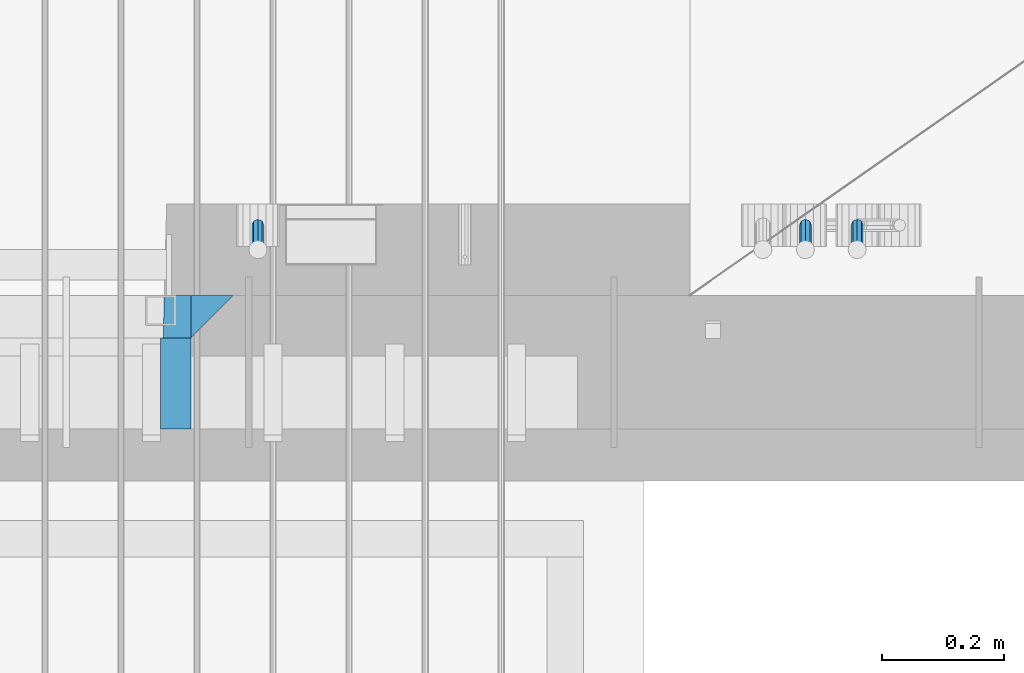
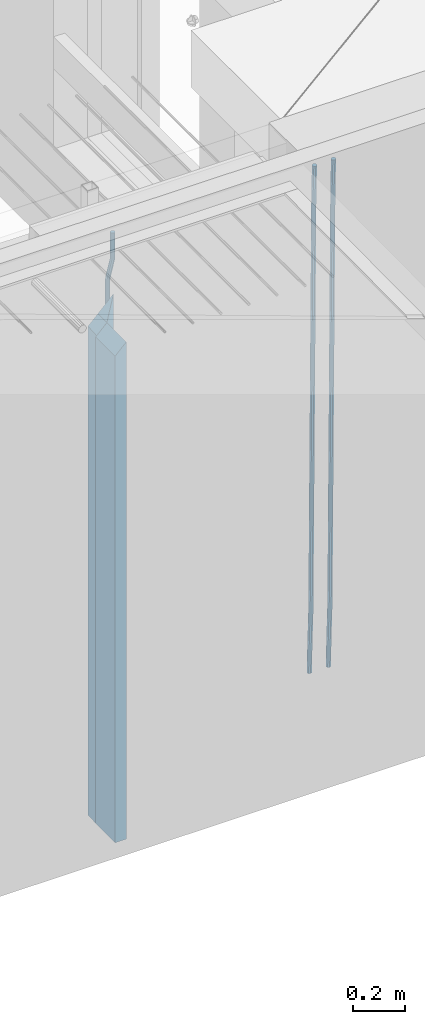
# One storey, part 130 of 349: 6 beams, 1 element without a shape of its own.
"""IFC2X3 building model written with IfcOpenShell, lengths in millimetres."""

from ifc_helpers import new_model, si_unit, frame, origin_with_axes, place, context, subcontext, project, spatial, faceted_brep, material, type_object, element, aggregate, save


model = new_model("IFC2X3")

# Units and contexts
model_context = context("Model", 3, precision=1e-05, world=origin_with_axes())
body_context = subcontext(model_context, "Body", "Model", "MODEL_VIEW")
ifc_project = project(units=[si_unit("LENGTHUNIT", "METRE", prefix="MILLI"), si_unit("AREAUNIT", "SQUARE_METRE"), si_unit("VOLUMEUNIT", "CUBIC_METRE"), si_unit("MASSUNIT", "GRAM", prefix="KILO"), si_unit("TIMEUNIT", "SECOND"), si_unit("PLANEANGLEUNIT", "RADIAN"), si_unit("SOLIDANGLEUNIT", "STERADIAN"), si_unit("THERMODYNAMICTEMPERATUREUNIT", "DEGREE_CELSIUS"), si_unit("LUMINOUSINTENSITYUNIT", "LUMEN")], contexts=[model_context])

# Site, building, storey
site_placement = place(None, origin_with_axes())
site = spatial("IfcSite", under=ifc_project, at=site_placement, CompositionType="ELEMENT")
building_placement = place(site_placement, origin_with_axes())
building = spatial("IfcBuilding", under=site, at=building_placement, CompositionType="ELEMENT")
storey_placement = place(building_placement, origin_with_axes())
storey = spatial("IfcBuildingStorey", under=building, at=storey_placement, Name="4", CompositionType="ELEMENT", Elevation=0.0)

# Assembly, beams
assembly_placement = place(storey_placement, origin_with_axes())
assembly = element("IfcElementAssembly", 1, at=assembly_placement, inside=storey, AssemblyPlace="NOTDEFINED", PredefinedType="REINFORCEMENT_UNIT")
ifc_material_1 = material(Name="CONCRETE/C35/45")
beam_type_1 = type_object("IfcBeamType", PredefinedType="NOTDEFINED")
beam_1_placement = place(assembly_placement, frame((33199.9988923323, 7815.0, 93175.0), z_axis=(-1.0, 3.00000001838171e-08, 0.0), x_axis=(0.0, 0.0, -1.0)))
beam_1 = element("IfcBeam", 2, at=beam_1_placement, type_object=beam_type_1, material=ifc_material_1, Name="SK", context=body_context, shape_type="Brep", body=[
    faceted_brep([(2420.0, -35.0, 35.0), (2420.0, -35.0, -35.0), (2420.0, 35.0, 35.0), (0.0, -35.0, -35.0), (70.0000000000164, 35.0, 35.0), (70.0000000000164, -35.0, 35.0)], [[[0, 1, 2]], [[2, 1, 3, 4]], [[0, 2, 4, 5]], [[1, 0, 5, 3]], [[5, 4, 3]]]),
])
beam_type_2 = type_object("IfcBeamType", PredefinedType="NOTDEFINED")
beam_2_placement = place(assembly_placement, frame((33139.9988923323, 7815.0, 93105.0), z_axis=(-1.0, 3.00000001838171e-08, 0.0), x_axis=(0.0, 0.0, -1.0)))
beam_2 = element("IfcBeam", 3, at=beam_2_placement, type_object=beam_type_2, material=ifc_material_1, Name="SK", context=body_context, shape_type="Brep", body=[
    faceted_brep([(2350.0, -35.0, -25.0), (2350.0, 35.0, -25.0), (2350.0, 35.0, 20.6410256410309), (2350.0, -35.0, 18.8461538461561), (0.0, -35.0, -25.0), (0.0, 35.0, -25.0), (45.6410256410309, 35.0, 20.6410256410254), (43.8461538461561, -35.0, 18.8461538461543)], [[[0, 1, 2, 3]], [[1, 0, 4, 5]], [[2, 1, 5, 6]], [[3, 2, 6, 7]], [[0, 3, 7, 4]], [[6, 5, 4, 7]]]),
])
ifc_material_2 = material(Name="TIMBER")
beam_type_3 = type_object("IfcBeamType", Name="50X150", PredefinedType="NOTDEFINED")
beam_3_placement = place(assembly_placement, frame((33139.9988923323, 7705.0, 93105.0), z_axis=(-1.0, 3.00000001838171e-08, 0.0), x_axis=(0.0, 0.0, -1.0)))
beam_3 = element("IfcBeam", 4, at=beam_3_placement, type_object=beam_type_3, material=ifc_material_2, ObjectType="50X150", context=body_context, shape_type="Brep", body=[
    faceted_brep([(2345.0, -75.0, 25.0), (2345.0, -75.0, -25.0), (2345.0, 75.0, -25.0), (2345.0, 75.0, 25.0), (0.0, -75.0, -25.0), (0.0, 75.0, -25.0), (50.0000000000036, 75.0, 25.0), (50.0000000000036, -75.0, 25.0)], [[[0, 1, 2, 3]], [[4, 5, 2, 1]], [[3, 2, 5, 6]], [[0, 3, 6, 7]], [[1, 0, 7, 4]], [[7, 6, 5, 4]]]),
])
ifc_material_3 = material()
beam_type_4 = type_object("IfcBeamType", Name="D20", PredefinedType="NOTDEFINED")
beam_4_placement = place(assembly_placement, frame((33274.9999999916, 7925.0, 93407.5), z_axis=(0.000415599999849905, 0.999999913638203, 4.76000000899737e-07), x_axis=(0.0, 0.0, -1.0)))
beam_4 = element("IfcBeam", 5, at=beam_4_placement, type_object=beam_type_4, material=ifc_material_3, Name="JM20", ObjectType="D20", context=body_context, shape_type="Brep", body=[
    faceted_brep([(0.0, -10.0, 0.0), (-4.19531716033816e-08, -7.07106781186667, -7.07106781187031), (113.248091332178, -7.0710684840451, -7.0710678117357), (113.248091314759, -10.0000006713562, -2.51020537689328e-10), (0.0, 0.0, -10.0), (113.248091374131, -6.72178430249915e-07, -9.99999999986903), (4.196772351861e-08, 7.07106781186303, -7.07106781186667), (113.248091416113, 7.07106713968824, -7.07106781173934), (0.0, 10.0, 0.0), (113.248091433488, 9.99999932782521, 1.30967237055302e-10), (4.196772351861e-08, 7.07106781185939, 7.07106781185939), (113.248091416113, 7.0710671396846, 7.071067811994), (0.0, 0.0, 10.0), (113.248091374131, -6.72174792271107e-07, 10.0000000001273), (-4.19531716033816e-08, -7.07106781187031, 7.07106781185939), (113.248091332178, -7.0710684840451, 7.071067811994), (130.699843527167, -7.06993249763036, -4.33745683788584), (128.538066582521, -9.99900540317321, 2.39499413731755), (131.594536475241, 0.00119355250353692, -7.12624594330919), (130.698046432328, 7.07220300913468, -4.33773834422391), (128.535525107087, 10.0009944322555, 2.39459602660281), (126.373748162892, 7.07192152754578, 9.1270470011732), (125.479055214906, 0.000795477419160306, 11.9158361066184), (126.37554525779, -7.07021397921199, 9.12732850753673), (240.336258550378, -7.05529970173666, 30.8729495437874), (238.174481606227, -9.98437260450009, 37.6054005176375), (241.230951498423, 0.0158263482953771, 28.0841604381058), (240.334461455612, 7.0868358050102, 30.8726680369582), (238.171940130502, 10.0156272283348, 37.6050024077231), (236.010163186409, 7.08655432384694, 44.3374533824244), (235.115470238379, 0.0154282738185429, 47.1262424881097), (236.011960281176, -7.05558118289991, 44.3377348892536), (253.461915329972, -7.05444528127919, 32.9289287376414), (253.46191532613, -9.98337746617108, 39.9999965521893), (253.461915339081, 0.0166225284556276, 29.9999965443676), (253.461915348205, 7.08769034247234, 32.9289287273205), (253.461915352003, 10.0166225357716, 39.9999965370152), (253.461915348293, 7.08769035281148, 47.0710643509774), (253.461915339183, 0.0166225430875784, 49.999996544273), (253.46191533003, -7.05444527093641, 47.0710643613093), (2417.50000002384, -7.0544364694706, 32.9289287374122), (2417.5000000337, -9.98336865393321, 39.9999965507959), (2417.49999999997, 0.0166313408753922, 29.9999965456082), (2417.49999997609, 7.08769915426274, 32.9289287300708), (2417.4999999662, 10.0166313460668, 39.9999965404204), (2417.49999997608, 7.08769916160054, 47.0710643538114), (2417.49999999994, 0.0166313512581837, 49.9999965456154), (2417.50000002382, -7.05443646212916, 47.0710643611455)], [[[0, 1, 2, 3]], [[1, 4, 5, 2]], [[4, 6, 7, 5]], [[6, 8, 9, 7]], [[8, 10, 11, 9]], [[10, 12, 13, 11]], [[12, 14, 15, 13]], [[14, 0, 3, 15]], [[14, 12, 10, 8, 6, 4, 1, 0]], [[3, 2, 16, 17]], [[2, 5, 18, 16]], [[5, 7, 19, 18]], [[7, 9, 20, 19]], [[9, 11, 21, 20]], [[11, 13, 22, 21]], [[13, 15, 23, 22]], [[15, 3, 17, 23]], [[17, 16, 24, 25]], [[16, 18, 26, 24]], [[18, 19, 27, 26]], [[19, 20, 28, 27]], [[20, 21, 29, 28]], [[21, 22, 30, 29]], [[22, 23, 31, 30]], [[23, 17, 25, 31]], [[25, 24, 32, 33]], [[24, 26, 34, 32]], [[26, 27, 35, 34]], [[27, 28, 36, 35]], [[28, 29, 37, 36]], [[29, 30, 38, 37]], [[30, 31, 39, 38]], [[31, 25, 33, 39]], [[33, 32, 40, 41]], [[32, 34, 42, 40]], [[34, 35, 43, 42]], [[35, 36, 44, 43]], [[36, 37, 45, 44]], [[37, 38, 46, 45]], [[38, 39, 47, 46]], [[39, 33, 41, 47]], [[42, 43, 44, 45, 46, 47, 41, 40]]]),
])
beam_5_placement = place(assembly_placement, frame((34259.9999999961, 7965.00000227913, 90990.0), z_axis=(0.00020576299992186, -0.999642804629538, -0.0267249099901004), x_axis=(-4.30000201928125e-08, -0.0267249099948059, 0.999642825806181)))
beam_5 = element("IfcBeam", 6, at=beam_5_placement, type_object=beam_type_4, material=ifc_material_3, Name="JM20", ObjectType="D20", context=body_context, shape_type="Brep", body=[
    faceted_brep([(0.0, -10.0, 0.0), (-4.19531716033816e-08, -7.07106781186667, -7.07106781187031), (60.4266690400545, -7.0710677960451, -7.07106780570757), (60.4266690441291, -9.99999998418934, 6.15546014159918e-09), (0.0, 0.0, -10.0), (60.426669036824, 1.58106558956206e-08, -9.99999999384454), (4.196772351861e-08, 7.07106781186303, -7.07106781186667), (60.4266690363438, 7.07106782768096, -7.07106780570757), (0.0, 10.0, 0.0), (60.4266690388904, 10.0000000158179, 6.15182216279209e-09), (4.196772351861e-08, 7.07106781185939, 7.07106781185939), (60.4266690429649, 7.07106782768096, 7.07106781802577), (0.0, 0.0, 10.0), (60.4266690461809, 1.58179318532348e-08, 10.0000000061555), (-4.19531716033816e-08, -7.07106781187031, 7.07106781185939), (60.4266690466611, -7.07106779605238, 7.07106781802213), (61.0378400410118, -7.07106779588503, -7.07106780564936), (60.991799419251, -9.99999998403655, 6.21366780251265e-09), (61.0569027789461, 1.5985278878361e-08, -9.99999999378269), (61.0378209396877, 7.07106782784831, -7.07106780564936), (60.9917724058905, 10.0000000159635, 6.21366780251265e-09), (60.9457317841297, 7.07106782781193, 7.0710678180767), (60.9266690461809, 1.59488990902901e-08, 10.0000000062028), (60.9457508854539, -7.07106779591413, 7.0710678180767), (61.6489592143771, -7.07106614513759, -7.06310863441468), (61.5568818710308, -9.9999984576425, 0.00735959856683621), (61.6870830769039, 1.71821739058942e-06, -9.99179257185824), (61.6489210170112, 7.07106947854481, -7.06310888312146), (61.556827851804, 10.0000015422847, 0.00735924683976918), (61.4647505084577, 7.07106922979438, 7.07782747982128), (61.4266266459163, 1.36643211590126e-06, 10.0065114172685), (61.464788705809, -7.07106639389531, 7.07782772852806), (176.543135720174, -7.07075579406956, -5.56673531796696), (176.451058376813, -9.99968810657447, 1.50373291501455), (176.581259582701, 0.000312069292704109, -8.49541925541052), (176.543097522794, 7.07137982961285, -5.56673556667374), (176.451004357587, 10.00031189336, 1.50373256329476), (176.35892701424, 7.07137958085514, 8.57420079627263), (176.320803151699, 0.000311717507429421, 11.5028847337162), (176.358965211621, -7.07075604281999, 8.57420104497578), (177.098753836006, -7.07075429323595, -5.55949898843028), (176.98362511232, -9.99968666800123, 1.510669025065), (177.146421932586, 0.000313595905026887, -8.48805862247536), (177.098706077581, 7.07138133041735, -5.55949936166144), (176.983557571715, 10.0003133318824, 1.51066849724157), (176.868428848029, 7.07138095712435, 8.58083651073321), (176.820760751449, 0.000313067976094317, 11.5093961447819), (176.868476606425, -7.07075466652896, 8.58083688396073), (177.654312950661, -7.07075204110879, -5.54863964998367), (177.516135294456, -9.99968450931192, 1.52107783331303), (177.711524267797, 0.000315886711177882, -8.47701274570863), (177.654255632195, 7.07138358250813, -5.54864021007961), (177.516054233929, 10.0003154905207, 1.5210770412159), (177.377876577739, 7.0713830223176, 8.59079452451624), (177.320665260588, 0.000315094497636892, 11.5191676202448), (177.377933896176, -7.07075260129932, 8.59079508461218), (299.436796249574, -7.07025836271714, -3.1681962331204), (299.298618593355, -9.99919083092027, 3.90152125031091), (299.494007566798, 0.000809565110102994, -6.09656932889993), (299.436738931283, 7.07187726089978, -3.16819679320906), (299.298537533061, 10.0008091689197, 3.90152045822106), (299.160359876842, 7.07187670072017, 10.9712379416487), (299.103148559603, 0.000808772889286047, 13.8996110374392), (299.160417195119, -7.07025892290039, 10.9712385017483), (299.98743051647, -7.07025613056248, -3.15743315966392), (299.971788958996, -9.99918809853989, 3.91467979818117), (299.993912075952, 0.000811591617093654, -6.08679785393178), (299.987423933868, 7.07187949325817, -3.1574327280432), (299.971753863239, 10.0008119014747, 3.91467990454839), (299.95611230444, 7.07187992653053, 10.9867922621015), (299.949630744944, 0.000812204350950196, 13.9161569563694), (299.956118887014, -7.07025569729012, 10.9867918304735), (300.538107039494, -7.07025785017686, -3.16575821840888), (300.644985195438, -9.99919020432935, 3.90450175465594), (300.493854948218, 0.000810030429420294, -6.09435592770024), (300.538151196495, 7.071877773491, -3.16575855385963), (300.645047642858, 10.0008097955724, 3.90450128024895), (300.751925798773, 7.07187744142357, 10.9747612533101), (300.796177890064, 0.000809560813650023, 13.9033589625978), (300.751881641787, -7.07025818224065, 10.9747615887682), (2293.36490490142, -7.07648090940347, -33.2930642912361), (2293.47178305736, -10.0054132635523, -26.2228043181785), (2293.32065281013, -0.00541302880083094, -36.2216620005347), (2293.36494905842, 7.06565471425711, -33.2930646266868), (2293.47184550477, 9.99458673634581, -26.2228047925819), (2293.57872366071, 7.06565438219332, -19.1525448195243), (2293.62297575199, -0.00541349841296324, -16.2239471102366), (2293.57867950371, -7.0764812414709, -19.1525444840736), (2294.0658245362, -7.07648309818615, -33.3036607065333), (2294.05312277409, -10.0054150789219, -26.2315929392535), (2294.10928714235, -0.00541549149056664, -36.2335844756526), (2294.15805078732, 7.06565223761572, -33.3050546393533), (2294.18355038921, 9.99458451388637, -26.2335642579346), (2294.17084862708, 7.06565253314329, -19.1614964906439), (2294.12738602093, -0.00541507354500936, -16.2315727215355), (2294.07862237596, -7.07648280265857, -19.1601025578348), (2294.76670261032, -7.08562269121467, -33.294332712383), (2294.63442802057, -10.0129954178956, -26.2238563411993), (2294.89787471293, -0.0156988342423574, -36.2230891548279), (2294.95110548967, 7.05531064255774, -33.2944998654275), (2294.89521307347, 9.98530428734011, -26.2240927312887), (2294.76293848372, 7.0579315606592, -19.1536163601049), (2294.63176638114, -0.0119922963167483, -16.2248599176673), (2294.57853560438, -7.08300177311321, -19.1534492070678), (2316.52657204497, -7.36937582653991, -33.0047303660212), (2316.39429745522, -10.2967485532172, -25.9342539948302), (2316.65774414754, -0.299451969567599, -35.9334868084661), (2316.7109749243, 6.7715575072325, -33.0048975190657), (2316.65508250811, 9.70155115201487, -25.9344903849269), (2316.52280791836, 6.7741784253376, -18.8640140137468), (2316.39163581574, -0.295745431634714, -15.9352575713092), (2316.33840503903, -7.36675490843481, -18.863846860706), (2317.16202064224, -7.37766220584308, -32.9962731735213), (2317.05438744847, -10.3053562613532, -25.9254688497131), (2317.23607125619, -0.306993473008333, -35.925789846493), (2317.23316144495, 6.76474808850253, -32.9979477328052), (2317.15499573652, 9.6950321815566, -25.9278370341635), (2317.04736254275, 6.7673381260538, -18.8570327103698), (2316.97331192881, -0.303330606784584, -15.9275160373909), (2316.97622174003, -7.37507216829545, -18.8553581510787), (2317.79752306276, -7.37578610372293, -32.9880110666527), (2317.71453320107, -10.3033876998124, -25.9168792378296), (2317.81444760226, -0.305295583297266, -35.918287695793), (2317.75539265381, 6.76628640723357, -32.9911928173897), (2317.65495180529, 9.69652304524061, -25.9213789128698), (2317.5719619436, 6.76892144914746, -18.8502470840467), (2317.55503740412, -0.301569071270933, -15.9199704549137), (2317.61409235255, -7.3731510618054, -18.847065333317), (2417.8183084176, -7.07752398473531, -31.6906369377139), (2417.73531855589, -10.0051255808248, -24.6195051088798), (2417.83523295709, -0.007033464313281, -34.6209135668432), (2417.77617800863, 7.06454852621755, -31.6938186884508), (2417.67573716014, 9.99478516423187, -24.6240047839383), (2417.59274729842, 7.06718356813872, -17.5528729551006), (2417.57582275895, -0.00330695228694822, -14.6225963259749), (2417.6348777074, -7.07488894281778, -17.5496912043673)], [[[0, 1, 2, 3]], [[1, 4, 5, 2]], [[4, 6, 7, 5]], [[6, 8, 9, 7]], [[8, 10, 11, 9]], [[10, 12, 13, 11]], [[12, 14, 15, 13]], [[14, 0, 3, 15]], [[14, 12, 10, 8, 6, 4, 1, 0]], [[3, 2, 16, 17]], [[2, 5, 18, 16]], [[5, 7, 19, 18]], [[7, 9, 20, 19]], [[9, 11, 21, 20]], [[11, 13, 22, 21]], [[13, 15, 23, 22]], [[15, 3, 17, 23]], [[17, 16, 24, 25]], [[16, 18, 26, 24]], [[18, 19, 27, 26]], [[19, 20, 28, 27]], [[20, 21, 29, 28]], [[21, 22, 30, 29]], [[22, 23, 31, 30]], [[23, 17, 25, 31]], [[25, 24, 32, 33]], [[24, 26, 34, 32]], [[26, 27, 35, 34]], [[27, 28, 36, 35]], [[28, 29, 37, 36]], [[29, 30, 38, 37]], [[30, 31, 39, 38]], [[31, 25, 33, 39]], [[33, 32, 40, 41]], [[32, 34, 42, 40]], [[34, 35, 43, 42]], [[35, 36, 44, 43]], [[36, 37, 45, 44]], [[37, 38, 46, 45]], [[38, 39, 47, 46]], [[39, 33, 41, 47]], [[41, 40, 48, 49]], [[40, 42, 50, 48]], [[42, 43, 51, 50]], [[43, 44, 52, 51]], [[44, 45, 53, 52]], [[45, 46, 54, 53]], [[46, 47, 55, 54]], [[47, 41, 49, 55]], [[49, 48, 56, 57]], [[48, 50, 58, 56]], [[50, 51, 59, 58]], [[51, 52, 60, 59]], [[52, 53, 61, 60]], [[53, 54, 62, 61]], [[54, 55, 63, 62]], [[55, 49, 57, 63]], [[57, 56, 64, 65]], [[56, 58, 66, 64]], [[58, 59, 67, 66]], [[59, 60, 68, 67]], [[60, 61, 69, 68]], [[61, 62, 70, 69]], [[62, 63, 71, 70]], [[63, 57, 65, 71]], [[65, 64, 72, 73]], [[64, 66, 74, 72]], [[66, 67, 75, 74]], [[67, 68, 76, 75]], [[68, 69, 77, 76]], [[69, 70, 78, 77]], [[70, 71, 79, 78]], [[71, 65, 73, 79]], [[73, 72, 80, 81]], [[72, 74, 82, 80]], [[74, 75, 83, 82]], [[75, 76, 84, 83]], [[76, 77, 85, 84]], [[77, 78, 86, 85]], [[78, 79, 87, 86]], [[79, 73, 81, 87]], [[81, 80, 88, 89]], [[80, 82, 90, 88]], [[82, 83, 91, 90]], [[83, 84, 92, 91]], [[84, 85, 93, 92]], [[85, 86, 94, 93]], [[86, 87, 95, 94]], [[87, 81, 89, 95]], [[89, 88, 96, 97]], [[88, 90, 98, 96]], [[90, 91, 99, 98]], [[91, 92, 100, 99]], [[92, 93, 101, 100]], [[93, 94, 102, 101]], [[94, 95, 103, 102]], [[95, 89, 97, 103]], [[97, 96, 104, 105]], [[96, 98, 106, 104]], [[98, 99, 107, 106]], [[99, 100, 108, 107]], [[100, 101, 109, 108]], [[101, 102, 110, 109]], [[102, 103, 111, 110]], [[103, 97, 105, 111]], [[105, 104, 112, 113]], [[104, 106, 114, 112]], [[106, 107, 115, 114]], [[107, 108, 116, 115]], [[108, 109, 117, 116]], [[109, 110, 118, 117]], [[110, 111, 119, 118]], [[111, 105, 113, 119]], [[113, 112, 120, 121]], [[112, 114, 122, 120]], [[114, 115, 123, 122]], [[115, 116, 124, 123]], [[116, 117, 125, 124]], [[117, 118, 126, 125]], [[118, 119, 127, 126]], [[119, 113, 121, 127]], [[121, 120, 128, 129]], [[120, 122, 130, 128]], [[122, 123, 131, 130]], [[123, 124, 132, 131]], [[124, 125, 133, 132]], [[125, 126, 134, 133]], [[126, 127, 135, 134]], [[127, 121, 129, 135]], [[130, 131, 132, 133, 134, 135, 129, 128]]]),
])
beam_6_placement = place(assembly_placement, frame((34174.9999999961, 7965.00000227913, 90990.0), z_axis=(0.00020576299992186, -0.999642804629538, -0.0267249099901004), x_axis=(-4.30000201928125e-08, -0.0267249099948059, 0.999642825806181)))
beam_6 = element("IfcBeam", 7, at=beam_6_placement, type_object=beam_type_4, material=ifc_material_3, Name="JM20", ObjectType="D20", context=body_context, shape_type="Brep", body=[
    faceted_brep([(0.0, -10.0, 0.0), (-4.19531716033816e-08, -7.07106781186667, -7.07106781187031), (60.4266690400545, -7.0710677960451, -7.07106780570757), (60.4266690441291, -9.99999998418934, 6.15546014159918e-09), (0.0, 0.0, -10.0), (60.426669036824, 1.58106558956206e-08, -9.99999999384454), (4.196772351861e-08, 7.07106781186303, -7.07106781186667), (60.4266690363438, 7.07106782768096, -7.07106780570757), (0.0, 10.0, 0.0), (60.4266690388904, 10.0000000158179, 6.15182216279209e-09), (4.196772351861e-08, 7.07106781185939, 7.07106781185939), (60.4266690429649, 7.07106782768096, 7.07106781802577), (0.0, 0.0, 10.0), (60.4266690461809, 1.58179318532348e-08, 10.0000000061555), (-4.19531716033816e-08, -7.07106781187031, 7.07106781185939), (60.4266690466611, -7.07106779605238, 7.07106781802213), (61.0378400410118, -7.07106779588503, -7.07106780564936), (60.991799419251, -9.99999998403655, 6.21366780251265e-09), (61.0569027789461, 1.5985278878361e-08, -9.99999999378269), (61.0378209396877, 7.07106782784831, -7.07106780564936), (60.9917724058905, 10.0000000159635, 6.21366780251265e-09), (60.9457317841297, 7.07106782781193, 7.0710678180767), (60.9266690461809, 1.59488990902901e-08, 10.0000000062028), (60.9457508854539, -7.07106779591413, 7.0710678180767), (61.6489592143771, -7.07106614513759, -7.06310863441468), (61.5568818710308, -9.9999984576425, 0.00735959856683621), (61.6870830769039, 1.71821739058942e-06, -9.99179257185824), (61.6489210170112, 7.07106947854481, -7.06310888312146), (61.556827851804, 10.0000015422847, 0.00735924683976918), (61.4647505084577, 7.07106922979438, 7.07782747982128), (61.4266266459163, 1.36643211590126e-06, 10.0065114172685), (61.464788705809, -7.07106639389531, 7.07782772852806), (176.543135720174, -7.07075579406956, -5.56673531796696), (176.451058376813, -9.99968810657447, 1.50373291501455), (176.581259582701, 0.000312069292704109, -8.49541925541052), (176.543097522794, 7.07137982961285, -5.56673556667374), (176.451004357587, 10.00031189336, 1.50373256329476), (176.35892701424, 7.07137958085514, 8.57420079627263), (176.320803151699, 0.000311717507429421, 11.5028847337162), (176.358965211621, -7.07075604281999, 8.57420104497578), (177.098753836006, -7.07075429323595, -5.55949898843028), (176.98362511232, -9.99968666800123, 1.510669025065), (177.146421932586, 0.000313595905026887, -8.48805862247536), (177.098706077581, 7.07138133041735, -5.55949936166144), (176.983557571715, 10.0003133318824, 1.51066849724157), (176.868428848029, 7.07138095712435, 8.58083651073321), (176.820760751449, 0.000313067976094317, 11.5093961447819), (176.868476606425, -7.07075466652896, 8.58083688396073), (177.654312950661, -7.07075204110879, -5.54863964998367), (177.516135294456, -9.99968450931192, 1.52107783331303), (177.711524267797, 0.000315886711177882, -8.47701274570863), (177.654255632195, 7.07138358250813, -5.54864021007961), (177.516054233929, 10.0003154905207, 1.5210770412159), (177.377876577739, 7.0713830223176, 8.59079452451624), (177.320665260588, 0.000315094497636892, 11.5191676202448), (177.377933896176, -7.07075260129932, 8.59079508461218), (299.436796249574, -7.07025836271714, -3.1681962331204), (299.298618593355, -9.99919083092027, 3.90152125031091), (299.494007566798, 0.000809565110102994, -6.09656932889993), (299.436738931283, 7.07187726089978, -3.16819679320906), (299.298537533061, 10.0008091689197, 3.90152045822106), (299.160359876842, 7.07187670072017, 10.9712379416487), (299.103148559603, 0.000808772889286047, 13.8996110374392), (299.160417195119, -7.07025892290039, 10.9712385017483), (299.98743051647, -7.07025613056248, -3.15743315966392), (299.971788958996, -9.99918809853989, 3.91467979818117), (299.993912075952, 0.000811591617093654, -6.08679785393178), (299.987423933868, 7.07187949325817, -3.1574327280432), (299.971753863239, 10.0008119014747, 3.91467990454839), (299.95611230444, 7.07187992653053, 10.9867922621015), (299.949630744944, 0.000812204350950196, 13.9161569563694), (299.956118887014, -7.07025569729012, 10.9867918304735), (300.538107039494, -7.07025785017686, -3.16575821840888), (300.644985195438, -9.99919020432935, 3.90450175465594), (300.493854948218, 0.000810030429420294, -6.09435592770024), (300.538151196495, 7.071877773491, -3.16575855385963), (300.645047642858, 10.0008097955724, 3.90450128024895), (300.751925798773, 7.07187744142357, 10.9747612533101), (300.796177890064, 0.000809560813650023, 13.9033589625978), (300.751881641787, -7.07025818224065, 10.9747615887682), (2293.36490490142, -7.07648090940347, -33.2930642912361), (2293.47178305736, -10.0054132635523, -26.2228043181785), (2293.32065281013, -0.00541302880083094, -36.2216620005347), (2293.36494905842, 7.06565471425711, -33.2930646266868), (2293.47184550477, 9.99458673634581, -26.2228047925819), (2293.57872366071, 7.06565438219332, -19.1525448195243), (2293.62297575199, -0.00541349841296324, -16.2239471102366), (2293.57867950371, -7.0764812414709, -19.1525444840736), (2294.0658245362, -7.07648309818615, -33.3036607065333), (2294.05312277409, -10.0054150789219, -26.2315929392535), (2294.10928714235, -0.00541549149056664, -36.2335844756526), (2294.15805078732, 7.06565223761572, -33.3050546393533), (2294.18355038921, 9.99458451388637, -26.2335642579346), (2294.17084862708, 7.06565253314329, -19.1614964906439), (2294.12738602093, -0.00541507354500936, -16.2315727215355), (2294.07862237596, -7.07648280265857, -19.1601025578348), (2294.76670261032, -7.08562269121467, -33.294332712383), (2294.63442802057, -10.0129954178956, -26.2238563411993), (2294.89787471293, -0.0156988342423574, -36.2230891548279), (2294.95110548967, 7.05531064255774, -33.2944998654275), (2294.89521307347, 9.98530428734011, -26.2240927312887), (2294.76293848372, 7.0579315606592, -19.1536163601049), (2294.63176638114, -0.0119922963167483, -16.2248599176673), (2294.57853560438, -7.08300177311321, -19.1534492070678), (2316.52657204497, -7.36937582653991, -33.0047303660212), (2316.39429745522, -10.2967485532172, -25.9342539948302), (2316.65774414754, -0.299451969567599, -35.9334868084661), (2316.7109749243, 6.7715575072325, -33.0048975190657), (2316.65508250811, 9.70155115201487, -25.9344903849269), (2316.52280791836, 6.7741784253376, -18.8640140137468), (2316.39163581574, -0.295745431634714, -15.9352575713092), (2316.33840503903, -7.36675490843481, -18.863846860706), (2317.16202064224, -7.37766220584308, -32.9962731735213), (2317.05438744847, -10.3053562613532, -25.9254688497131), (2317.23607125619, -0.306993473008333, -35.925789846493), (2317.23316144495, 6.76474808850253, -32.9979477328052), (2317.15499573652, 9.6950321815566, -25.9278370341635), (2317.04736254275, 6.7673381260538, -18.8570327103698), (2316.97331192881, -0.303330606784584, -15.9275160373909), (2316.97622174003, -7.37507216829545, -18.8553581510787), (2317.79752306276, -7.37578610372293, -32.9880110666527), (2317.71453320107, -10.3033876998124, -25.9168792378296), (2317.81444760226, -0.305295583297266, -35.918287695793), (2317.75539265381, 6.76628640723357, -32.9911928173897), (2317.65495180529, 9.69652304524061, -25.9213789128698), (2317.5719619436, 6.76892144914746, -18.8502470840467), (2317.55503740412, -0.301569071270933, -15.9199704549137), (2317.61409235255, -7.3731510618054, -18.847065333317), (2417.8183084176, -7.07752398473531, -31.6906369377139), (2417.73531855589, -10.0051255808248, -24.6195051088798), (2417.83523295709, -0.007033464313281, -34.6209135668432), (2417.77617800863, 7.06454852621755, -31.6938186884508), (2417.67573716014, 9.99478516423187, -24.6240047839383), (2417.59274729842, 7.06718356813872, -17.5528729551006), (2417.57582275895, -0.00330695228694822, -14.6225963259749), (2417.6348777074, -7.07488894281778, -17.5496912043673)], [[[0, 1, 2, 3]], [[1, 4, 5, 2]], [[4, 6, 7, 5]], [[6, 8, 9, 7]], [[8, 10, 11, 9]], [[10, 12, 13, 11]], [[12, 14, 15, 13]], [[14, 0, 3, 15]], [[14, 12, 10, 8, 6, 4, 1, 0]], [[3, 2, 16, 17]], [[2, 5, 18, 16]], [[5, 7, 19, 18]], [[7, 9, 20, 19]], [[9, 11, 21, 20]], [[11, 13, 22, 21]], [[13, 15, 23, 22]], [[15, 3, 17, 23]], [[17, 16, 24, 25]], [[16, 18, 26, 24]], [[18, 19, 27, 26]], [[19, 20, 28, 27]], [[20, 21, 29, 28]], [[21, 22, 30, 29]], [[22, 23, 31, 30]], [[23, 17, 25, 31]], [[25, 24, 32, 33]], [[24, 26, 34, 32]], [[26, 27, 35, 34]], [[27, 28, 36, 35]], [[28, 29, 37, 36]], [[29, 30, 38, 37]], [[30, 31, 39, 38]], [[31, 25, 33, 39]], [[33, 32, 40, 41]], [[32, 34, 42, 40]], [[34, 35, 43, 42]], [[35, 36, 44, 43]], [[36, 37, 45, 44]], [[37, 38, 46, 45]], [[38, 39, 47, 46]], [[39, 33, 41, 47]], [[41, 40, 48, 49]], [[40, 42, 50, 48]], [[42, 43, 51, 50]], [[43, 44, 52, 51]], [[44, 45, 53, 52]], [[45, 46, 54, 53]], [[46, 47, 55, 54]], [[47, 41, 49, 55]], [[49, 48, 56, 57]], [[48, 50, 58, 56]], [[50, 51, 59, 58]], [[51, 52, 60, 59]], [[52, 53, 61, 60]], [[53, 54, 62, 61]], [[54, 55, 63, 62]], [[55, 49, 57, 63]], [[57, 56, 64, 65]], [[56, 58, 66, 64]], [[58, 59, 67, 66]], [[59, 60, 68, 67]], [[60, 61, 69, 68]], [[61, 62, 70, 69]], [[62, 63, 71, 70]], [[63, 57, 65, 71]], [[65, 64, 72, 73]], [[64, 66, 74, 72]], [[66, 67, 75, 74]], [[67, 68, 76, 75]], [[68, 69, 77, 76]], [[69, 70, 78, 77]], [[70, 71, 79, 78]], [[71, 65, 73, 79]], [[73, 72, 80, 81]], [[72, 74, 82, 80]], [[74, 75, 83, 82]], [[75, 76, 84, 83]], [[76, 77, 85, 84]], [[77, 78, 86, 85]], [[78, 79, 87, 86]], [[79, 73, 81, 87]], [[81, 80, 88, 89]], [[80, 82, 90, 88]], [[82, 83, 91, 90]], [[83, 84, 92, 91]], [[84, 85, 93, 92]], [[85, 86, 94, 93]], [[86, 87, 95, 94]], [[87, 81, 89, 95]], [[89, 88, 96, 97]], [[88, 90, 98, 96]], [[90, 91, 99, 98]], [[91, 92, 100, 99]], [[92, 93, 101, 100]], [[93, 94, 102, 101]], [[94, 95, 103, 102]], [[95, 89, 97, 103]], [[97, 96, 104, 105]], [[96, 98, 106, 104]], [[98, 99, 107, 106]], [[99, 100, 108, 107]], [[100, 101, 109, 108]], [[101, 102, 110, 109]], [[102, 103, 111, 110]], [[103, 97, 105, 111]], [[105, 104, 112, 113]], [[104, 106, 114, 112]], [[106, 107, 115, 114]], [[107, 108, 116, 115]], [[108, 109, 117, 116]], [[109, 110, 118, 117]], [[110, 111, 119, 118]], [[111, 105, 113, 119]], [[113, 112, 120, 121]], [[112, 114, 122, 120]], [[114, 115, 123, 122]], [[115, 116, 124, 123]], [[116, 117, 125, 124]], [[117, 118, 126, 125]], [[118, 119, 127, 126]], [[119, 113, 121, 127]], [[121, 120, 128, 129]], [[120, 122, 130, 128]], [[122, 123, 131, 130]], [[123, 124, 132, 131]], [[124, 125, 133, 132]], [[125, 126, 134, 133]], [[126, 127, 135, 134]], [[127, 121, 129, 135]], [[130, 131, 132, 133, 134, 135, 129, 128]]]),
])
aggregate(assembly, [beam_4, beam_5, beam_6, beam_1, beam_2, beam_3])

save(model, "model.ifc")
